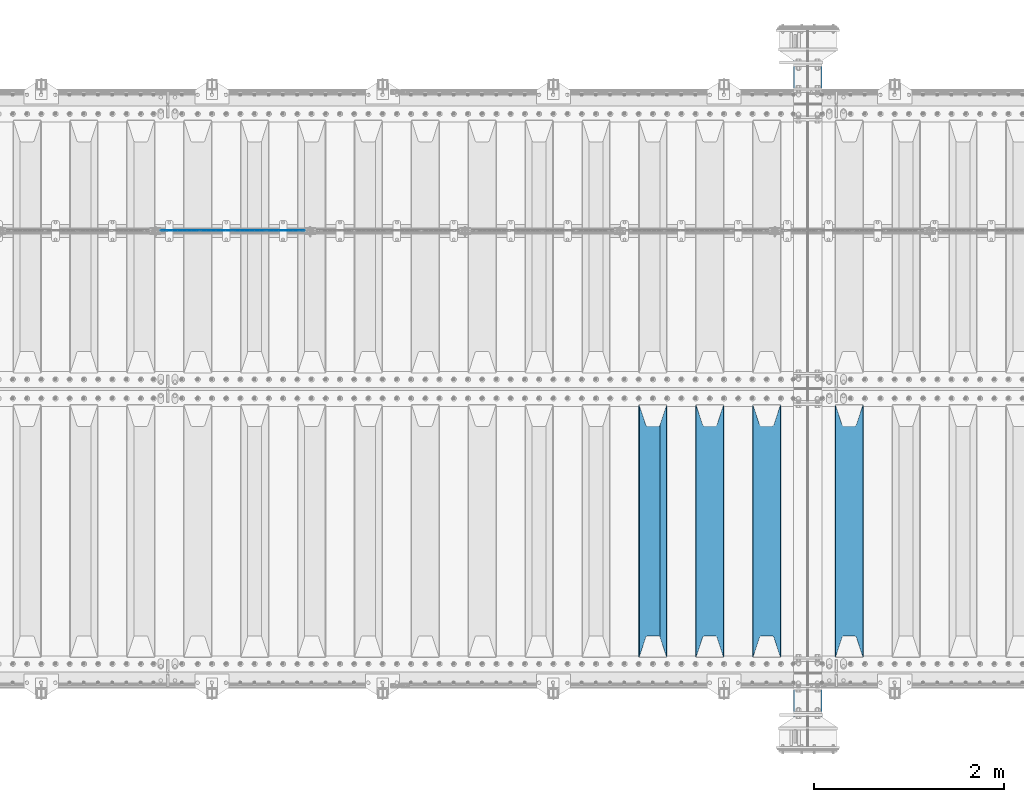
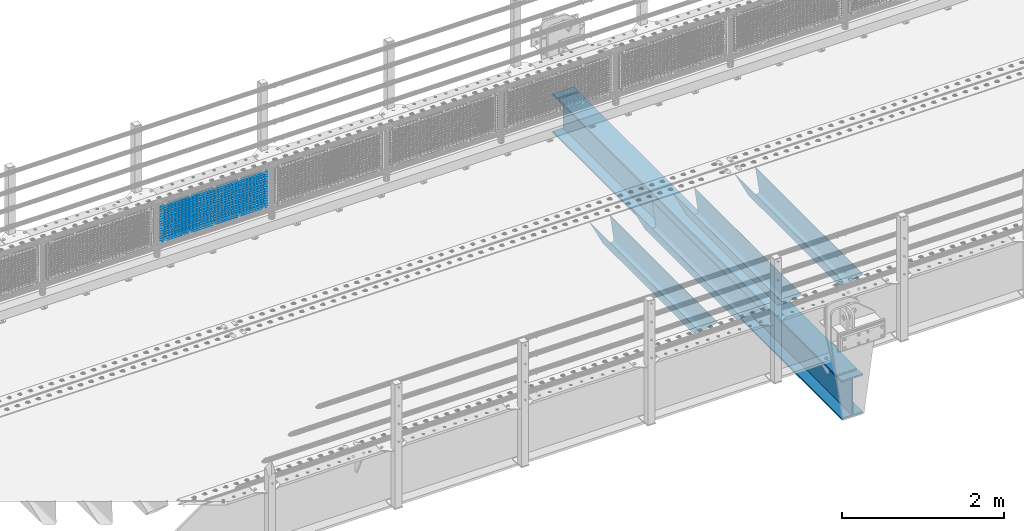
# One storey, part 121 of 242: 21 beams.
"""IFC2X3 building model written with IfcOpenShell, lengths in millimetres."""

import ifcopenshell
import ifcopenshell.guid

model = None  # the IFC model being written
_history = None  # IfcOwnerHistory: only IFC2X3 demands one
_inside = {}  # id of a spatial element -> (the spatial element, [elements in it])
_under = {}  # id of a project, library or spatial element -> (it, [spatial elements below it])
_declared = {}  # id of a project -> (the project, [libraries it declares])
_typed = {}  # id of a type object -> (the type object, [elements of that type])
_made_of = {}  # id of a material, layer set ... -> (it, [elements and type objects made of it])


def new_model(schema):
    """Start an empty IFC model of exactly this schema.

    Asked for "IFC4X3", IfcOpenShell would pick the latest addendum, in which some entities
    have other attributes; the version numbers below select the first issue.
    IFC2X3 requires an IfcOwnerHistory on every rooted entity: one is made here for all.
    """
    global model, _history
    if schema == "IFC4X3":
        model = ifcopenshell.file(schema_version=(4, 3, 0, 0))
    else:
        model = ifcopenshell.file(schema=schema)
    _inside.clear()
    _under.clear()
    _declared.clear()
    _typed.clear()
    _made_of.clear()
    _history = None
    if model.schema == "IFC2X3":
        org = make("IfcOrganization", Name="unknown")
        user = make(
            "IfcPersonAndOrganization",
            ThePerson=make("IfcPerson", FamilyName="unknown"),
            TheOrganization=org,
        )
        app = make(
            "IfcApplication",
            ApplicationDeveloper=org,
            Version="unknown",
            ApplicationFullName="unknown",
            ApplicationIdentifier="unknown",
        )
        _history = make(
            "IfcOwnerHistory",
            OwningUser=user,
            OwningApplication=app,
            ChangeAction="ADDED",
            CreationDate=0,
        )
    return model


def make(cls, **values):
    """One entity of the class cls with the attributes given. An attribute that is None is left unset."""
    return model.create_entity(
        cls, **{name: value for name, value in values.items() if value is not None}
    )


def rooted(cls, **values):
    """An entity with a GlobalId (a new one), such as an element, a storey or a relation."""
    return make(cls, GlobalId=ifcopenshell.guid.new(), OwnerHistory=_history, **values)


def si_unit(unit_type, name, prefix=None):
    """IfcSIUnit, for example si_unit("LENGTHUNIT", "METRE", prefix="MILLI")."""
    return make("IfcSIUnit", UnitType=unit_type, Prefix=prefix, Name=name)


def assignment(units):
    """IfcUnitAssignment: the units of a project."""
    return None if units is None else make("IfcUnitAssignment", Units=units)


def point(xyz):
    """IfcCartesianPoint."""
    return None if xyz is None else make("IfcCartesianPoint", Coordinates=xyz)


def direction(xyz):
    """IfcDirection."""
    return None if xyz is None else make("IfcDirection", DirectionRatios=xyz)


def frame(location, z_axis=None, x_axis=None):
    """IfcAxis2Placement3D, a coordinate frame: its origin and axes. An axis left out is left unset."""
    return make(
        "IfcAxis2Placement3D",
        Location=point(location),
        Axis=direction(z_axis),
        RefDirection=direction(x_axis),
    )


def origin_with_axes():
    """The frame at (0, 0, 0) with the z axis (0, 0, 1) and the x axis (1, 0, 0) written out."""
    return frame((0.0, 0.0, 0.0), z_axis=(0.0, 0.0, 1.0), x_axis=(1.0, 0.0, 0.0))


def place(relative_to, where):
    """IfcLocalPlacement: puts the frame where relative to a parent placement (None: the world)."""
    return make(
        "IfcLocalPlacement", PlacementRelTo=relative_to, RelativePlacement=where
    )


def context(
    kind, dimensions, precision=None, world=None, true_north=None, identifier=None
):
    """IfcGeometricRepresentationContext, for example the 3D "Model" context."""
    return make(
        "IfcGeometricRepresentationContext",
        ContextIdentifier=identifier,
        ContextType=kind,
        CoordinateSpaceDimension=dimensions,
        Precision=precision,
        WorldCoordinateSystem=world,
        TrueNorth=true_north,
    )


def subcontext(parent, identifier, kind, view, scale=None):
    """IfcGeometricRepresentationSubContext, for example "Body" below "Model"."""
    return make(
        "IfcGeometricRepresentationSubContext",
        ContextIdentifier=identifier,
        ContextType=kind,
        ParentContext=parent,
        TargetScale=scale,
        TargetView=view,
    )


def project(units=None, contexts=None):
    """IfcProject with its units and contexts."""
    return rooted(
        "IfcProject",
        Name="project",
        RepresentationContexts=contexts,
        UnitsInContext=assignment(units),
    )


def spatial(cls, under=None, at=None, **own):
    """A site, building, storey or space (cls), placed at a placement, below another one or the project."""
    s = rooted(cls, ObjectPlacement=at, **own)
    if under is not None:
        _under.setdefault(under.id(), (under, []))[1].append(s)
    return s


def faces_of(points, faces, orient=None, outer=None):
    """IfcFace entities. A face is a list of loops; a loop is a list of indices into points, from 0.

    orient and outer hold one flag for each loop. By default every Orientation is true, the
    first loop of a face is its IfcFaceOuterBound and the others are IfcFaceBound.
    """
    made = []
    for i, loops in enumerate(faces):
        bounds = []
        for j, loop in enumerate(loops):
            is_outer = j == 0 if outer is None else outer[i][j]
            bounds.append(
                make(
                    "IfcFaceOuterBound" if is_outer else "IfcFaceBound",
                    Bound=make("IfcPolyLoop", Polygon=[points[k] for k in loop]),
                    Orientation=True if orient is None else orient[i][j],
                )
            )
        made.append(make("IfcFace", Bounds=bounds))
    return made


def faceted_brep(points, faces, orient=None, outer=None, voids=None):
    """IfcFacetedBrep: a solid bounded by flat faces; with voids (closed shells), ...WithVoids."""
    shared = [point(p) for p in points]
    hull = make("IfcClosedShell", CfsFaces=faces_of(shared, faces, orient, outer))
    if voids is None:
        return make("IfcFacetedBrep", Outer=hull)
    return make(
        "IfcFacetedBrepWithVoids",
        Outer=hull,
        Voids=[
            make(cls, CfsFaces=faces_of(shared, fs, o, b)) for cls, fs, o, b in voids
        ],
    )


def shape(context_of_items, identifier, shape_type, items):
    """IfcShapeRepresentation: the items that make up one representation, for example the "Body"."""
    return make(
        "IfcShapeRepresentation",
        ContextOfItems=context_of_items,
        RepresentationIdentifier=identifier,
        RepresentationType=shape_type,
        Items=items,
    )


def material(Name=None, Category=None):
    """IfcMaterial."""
    return make("IfcMaterial", Name=Name, Category=Category)


def made_of(thing, what):
    """Note that an element or type object is made of a material, layer set ...; save() writes the relation."""
    if what is not None:
        _made_of.setdefault(what.id(), (what, []))[1].append(thing)
    return thing


def type_object(cls, material=None, **own):
    """A type object (cls), such as IfcWallType, which elements share."""
    return made_of(rooted(cls, **own), material)


def element(
    cls,
    number,
    at=None,
    inside=None,
    cuts=None,
    type_object=None,
    material=None,
    context=None,
    identifier="Body",
    shape_type=None,
    held_by="IfcProductDefinitionShape",
    body=None,
    shapes=None,
    **own,
):
    """One element of the class cls, such as IfcWall. Its Tag is "e" and its number.

    at: its placement. inside: the storey or other place that contains it. cuts: it is an
    opening in that element (IfcRelVoidsElement). A single representation is given by context,
    identifier, shape_type and body (its items); several are given by shapes. held_by: the class
    of the entity that holds the representations. save() writes the other relations.
    """
    e = rooted(cls, Tag="e%d" % number, ObjectPlacement=at, **own)
    if body is not None:
        shapes = [shape(context, identifier, shape_type, body)]
    if shapes is not None:
        e.Representation = make(held_by, Representations=shapes)
    if inside is not None:
        _inside.setdefault(inside.id(), (inside, []))[1].append(e)
    if cuts is not None:
        rooted(
            "IfcRelVoidsElement", RelatingBuildingElement=cuts, RelatedOpeningElement=e
        )
    if type_object is not None:
        _typed.setdefault(type_object.id(), (type_object, []))[1].append(e)
    return made_of(e, material)


def aggregate(whole, parts):
    """IfcRelAggregates: a whole, such as a stair, and the parts it consists of."""
    return rooted("IfcRelAggregates", RelatingObject=whole, RelatedObjects=parts)


def save(model, path):
    """Write the relations noted so far, then the file.

    IfcRelAggregates (storeys below a building ...), IfcRelContainedInSpatialStructure (elements
    in a storey), IfcRelDefinesByType, IfcRelAssociatesMaterial and IfcRelDeclares: one each for
    every whole, place, type object, material and project.
    """
    for whole, parts in _under.values():
        aggregate(whole, parts)
    for where, things in _inside.values():
        rooted(
            "IfcRelContainedInSpatialStructure",
            RelatedElements=things,
            RelatingStructure=where,
        )
    for kind, things in _typed.values():
        rooted("IfcRelDefinesByType", RelatedObjects=things, RelatingType=kind)
    for what, things in _made_of.values():
        rooted("IfcRelAssociatesMaterial", RelatedObjects=things, RelatingMaterial=what)
    for by, libraries in _declared.values():
        rooted("IfcRelDeclares", RelatingContext=by, RelatedDefinitions=libraries)
    model.write(path)


model = new_model("IFC2X3")

# Units and contexts
model_context = context("Model", 3, precision=1e-05, world=origin_with_axes())
body_context = subcontext(model_context, "Body", "Model", "MODEL_VIEW")
ifc_project = project(units=[si_unit("LENGTHUNIT", "METRE", prefix="MILLI"), si_unit("AREAUNIT", "SQUARE_METRE"), si_unit("VOLUMEUNIT", "CUBIC_METRE"), si_unit("MASSUNIT", "GRAM", prefix="KILO"), si_unit("TIMEUNIT", "SECOND"), si_unit("PLANEANGLEUNIT", "RADIAN"), si_unit("SOLIDANGLEUNIT", "STERADIAN"), si_unit("THERMODYNAMICTEMPERATUREUNIT", "DEGREE_CELSIUS"), si_unit("LUMINOUSINTENSITYUNIT", "LUMEN")], contexts=[model_context])

# Site, building, storey
site_placement = place(None, origin_with_axes())
site = spatial("IfcSite", under=ifc_project, at=site_placement, CompositionType="ELEMENT")
building_placement = place(site_placement, origin_with_axes())
building = spatial("IfcBuilding", under=site, at=building_placement, Name="Standard", CompositionType="ELEMENT")
storey_placement = place(building_placement, origin_with_axes())
storey = spatial("IfcBuildingStorey", under=building, at=storey_placement, Name="Undefined", CompositionType="ELEMENT", Elevation=0.0)

# Beams
ifc_material_1 = material(Name="Misc_Undefined")
beam_type_1 = type_object("IfcBeamType", Name="D3", PredefinedType="NOTDEFINED")
for number, where, z_axis, x_axis in (
    (1, (-35242.0, -19329.5, 851.596999999999), (0.0, 0.0, 1.0), (1.0, 0.0, 0.0)),
    (2, (-35242.0, -19329.5, 669.452), (0.0, 0.0, 1.0), (1.0, 0.0, 0.0)),
    (3, (-35242.0, -19329.5, 523.736), (0.0, 0.0, 1.0), (1.0, 0.0, 0.0)),
    (4, (-35242.0, -19329.5, 487.307), (0.0, 0.0, 1.0), (1.0, 0.0, 0.0)),
    (5, (-35242.0, -19329.5, 705.881), (0.0, 0.0, 1.0), (1.0, 0.0, 0.0)),
    (6, (-35242.0, -19329.5, 596.594), (0.0, 0.0, 1.0), (1.0, 0.0, 0.0)),
    (7, (-35242.0, -19329.5, 450.878), (0.0, 0.0, 1.0), (1.0, 0.0, 0.0)),
    (8, (-35242.0, -19329.5, 815.167999999999), (0.0, 0.0, 1.0), (1.0, 0.0, 0.0)),
    (9, (-35242.0, -19329.5, 888.025999999999), (0.0, 0.0, 1.0), (1.0, 0.0, 0.0)),
    (10, (-35242.0, -19329.5, 778.738999999999), (0.0, 0.0, 1.0), (1.0, 0.0, 0.0)),
    (11, (-35242.0, -19329.5, 742.309999999999), (0.0, 0.0, 1.0), (1.0, 0.0, 0.0)),
    (12, (-35242.0, -19329.5, 633.023), (0.0, 0.0, 1.0), (1.0, 0.0, 0.0)),
    (13, (-35242.0, -19329.5, 560.165), (0.0, 0.0, 1.0), (1.0, 0.0, 0.0)),
    (14, (-35242.0, -19329.5, 414.449), (0.0, 0.0, 1.0), (1.0, 0.0, 0.0)),
):
    element("IfcBeam", number, at=place(storey_placement, frame(where, z_axis=z_axis, x_axis=x_axis)), inside=storey, type_object=beam_type_1, material=ifc_material_1, ObjectType="D3", context=body_context, shape_type="Brep", body=[
        faceted_brep([(0.0, -1.50000000000364, 0.0), (-3.63797880709171e-12, -0.750000000003638, -1.29903810567669), (1523.0, -0.75, -1.29903810567669), (1523.0, -1.5, 0.0), (0.0, 0.749999999996362, -1.29903810567669), (1523.0, 0.75, -1.29903810567669), (-3.63797880709171e-12, 1.49999999999636, 0.0), (1523.0, 1.5, 0.0), (0.0, 0.749999999996362, 1.29903810567669), (1523.0, 0.75, 1.29903810567669), (-3.63797880709171e-12, -0.750000000003638, 1.29903810567669), (1523.0, -0.75, 1.29903810567669)], [[[0, 1, 2, 3]], [[1, 4, 5, 2]], [[4, 6, 7, 5]], [[6, 8, 9, 7]], [[8, 10, 11, 9]], [[10, 0, 3, 11]], [[5, 7, 9, 11, 3, 2]], [[10, 8, 6, 4, 1, 0]]]),
    ])
beam_1_placement = place(storey_placement, frame((-35217.0, -19329.5, 353.02), z_axis=(0.0, 0.0, 1.0), x_axis=(1.0, 0.0, 0.0)))
element("IfcBeam", 15, at=beam_1_placement, inside=storey, type_object=beam_type_1, material=ifc_material_1, ObjectType="D3", context=body_context, shape_type="Brep", body=[
    faceted_brep([(0.0, -1.50000000000364, 0.0), (-3.63797880709171e-12, -0.750000000003638, -1.29903810567669), (1473.0, -0.75, -1.29903810567669), (1473.0, -1.5, 0.0), (0.0, 0.749999999996362, -1.29903810567669), (1473.0, 0.75, -1.29903810567663), (-3.63797880709171e-12, 1.49999999999636, 0.0), (1473.0, 1.5, 0.0), (0.0, 0.749999999996362, 1.29903810567669), (1473.0, 0.75, 1.29903810567669), (-3.63797880709171e-12, -0.750000000003638, 1.29903810567669), (1473.0, -0.75, 1.29903810567669)], [[[0, 1, 2, 3]], [[1, 4, 5, 2]], [[4, 6, 7, 5]], [[6, 8, 9, 7]], [[8, 10, 11, 9]], [[10, 0, 3, 11]], [[5, 7, 9, 11, 3, 2]], [[10, 8, 6, 4, 1, 0]]]),
])
beam_2_placement = place(storey_placement, frame((-35242.0, -19329.5, 378.02), z_axis=(0.0, 0.0, 1.0), x_axis=(1.0, 0.0, 0.0)))
element("IfcBeam", 16, at=beam_2_placement, inside=storey, type_object=beam_type_1, material=ifc_material_1, ObjectType="D3", context=body_context, shape_type="Brep", body=[
    faceted_brep([(0.0, -1.50000000000364, 0.0), (-3.63797880709171e-12, -0.750000000003638, -1.29903810567669), (1523.0, -0.75, -1.29903810567669), (1523.0, -1.5, 0.0), (0.0, 0.749999999996362, -1.29903810567669), (1523.0, 0.75, -1.29903810567669), (-3.63797880709171e-12, 1.49999999999636, 0.0), (1523.0, 1.5, 0.0), (0.0, 0.749999999996362, 1.29903810567669), (1523.0, 0.75, 1.29903810567669), (-3.63797880709171e-12, -0.750000000003638, 1.29903810567669), (1523.0, -0.75, 1.29903810567669)], [[[0, 1, 2, 3]], [[1, 4, 5, 2]], [[4, 6, 7, 5]], [[6, 8, 9, 7]], [[8, 10, 11, 9]], [[10, 0, 3, 11]], [[5, 7, 9, 11, 3, 2]], [[10, 8, 6, 4, 1, 0]]]),
])
ifc_material_2 = material(Name="STEEL/S355N")
beam_type_2 = type_object("IfcBeamType", Name="HEA600", PredefinedType="NOTDEFINED")
beam_3_placement = place(storey_placement, frame((-28415.0000001802, -24564.9999999649, -1195.00001822199), z_axis=(0.0, 0.0, 1.0), x_axis=(0.0, 1.0, 0.0)))
element("IfcBeam", 17, at=beam_3_placement, inside=storey, type_object=beam_type_2, material=ifc_material_2, ObjectType="HEA600", context=body_context, shape_type="Brep", body=[
    faceted_brep([(6989.99999999952, -150.000000004802, 295.0), (6989.99999999952, -150.0, 270.0), (6989.99999999952, -6.5, 270.0), (6989.99999999952, -6.5, 295.0), (7019.99999999952, -6.5, 270.0), (7019.99999999952, -6.5, 295.0), (7019.99999999952, -150.0, 295.0), (7019.99999999952, -150.0, 270.0), (7129.99999999952, -150.0, 270.0), (7129.99999999952, -150.0, 295.0), (7129.99999999952, -6.5, 270.0), (7129.99999999952, 150.0, 295.0), (7129.99999999952, 150.0, 270.0), (7019.99999999952, 150.0, 270.0), (7019.99999999952, 150.0, 295.0), (140.000000044318, 6.5, 270.0), (140.000000324839, 150.0, 270.0), (6989.99999999952, 150.0, 270.0), (6989.99999999952, 6.5, 270.0), (0.0, -150.0, -295.0), (0.0, 150.0, -295.0), (7129.99999999952, 150.0, -295.0), (7129.99999999952, -150.0, -295.0), (7019.99999999952, -150.0, -270.0), (6989.99999999952, -150.0, -270.0), (139.999999738287, -150.0, -270.0), (109.999999738287, -150.0, -270.0), (0.0, -150.0, -270.0), (7129.99999999952, -150.0, -270.0), (7019.99999999952, -6.5, -270.0), (6989.99999999952, -6.5, -270.0), (140.000000025124, -6.5, -270.0), (110.000000025288, -6.5, -270.0), (0.0, -6.5, -270.0), (7129.99999999952, -6.5, -270.0), (0.0, -150.0, 270.0), (0.0, -6.5, 270.0), (110.000000025288, -6.5, 270.0), (109.999999738287, -150.0, 270.0), (139.999999738287, -150.00000023983, 295.0), (140.000000025124, -6.50000023983011, 295.0), (140.000000025124, -6.5, 270.0), (139.999999738287, -150.0, 270.0), (110.000000025288, -6.50000017982893, 295.0), (109.999999738287, -150.0, 295.0), (0.0, -150.0, 295.0), (0.0, 6.5, 270.0), (0.0, 150.0, 270.0), (110.000000324839, 150.0, 270.0), (110.000000324839, 6.5, 270.0), (0.0, 150.0, 295.0), (0.0, 6.5, -270.0), (0.0, 150.0, -270.0), (110.000000324839, 150.0, 295.0), (110.000000324839, 6.49999976097024, 295.0), (140.000000044318, 6.49999976097024, 295.0), (140.000000324839, 150.0, 295.0), (6989.99999999952, 150.0, 295.0), (6989.99999999952, 6.5, 295.0), (7019.99999999952, 6.5, 295.0), (7019.99999999952, 6.5, 270.0), (7129.99999999952, 6.5, 270.0), (7019.99999999952, 6.5, -270.0), (6989.99999999952, 6.5, -270.0), (140.000000044318, 6.5, -270.0), (110.000000324839, 6.5, -270.0), (7129.99999999952, 6.5, -270.0), (7019.99999999952, 150.0, -270.0), (6989.99999999952, 150.0, -270.0), (140.000000324839, 150.0, -270.0), (110.000000324839, 150.0, -270.0), (7129.99999999952, 150.0, -270.0)], [[[0, 1, 2, 3]], [[3, 2, 4, 5]], [[6, 5, 4, 7]], [[8, 9, 6, 7]], [[10, 8, 7, 4]], [[11, 12, 13, 14]], [[15, 16, 17, 18]], [[19, 20, 21, 22]], [[23, 24, 25, 26, 27, 19, 22, 28]], [[29, 30, 31, 32, 33, 27, 26, 25, 24, 23, 28, 34]], [[35, 36, 37, 38]], [[39, 40, 41, 42]], [[43, 37, 41, 40]], [[44, 38, 37, 43]], [[45, 35, 38, 44]], [[46, 47, 48, 49]], [[19, 27, 33, 36, 35, 45, 50, 47, 46, 51, 52, 20]], [[47, 50, 53, 48]], [[54, 49, 48, 53]], [[55, 15, 49, 54]], [[56, 16, 15, 55]], [[16, 56, 57, 17]], [[58, 18, 17, 57]], [[59, 60, 18, 58]], [[14, 13, 60, 59]], [[12, 61, 60, 13]], [[62, 63, 64, 65, 51, 46, 49, 15, 18, 60, 61, 66]], [[67, 68, 69, 70, 52, 51, 65, 64, 63, 62, 66, 71]], [[20, 52, 70, 69, 68, 67, 71, 21]], [[66, 61, 12, 11, 9, 8, 10, 34, 28, 22, 21, 71]], [[4, 2, 41, 37, 36, 33, 32, 31, 30, 29, 34, 10]], [[42, 41, 2, 1]], [[39, 42, 1, 0]], [[9, 11, 14, 59, 58, 57, 56, 55, 54, 53, 50, 45, 44, 43, 40, 39, 0, 3, 5, 6]]]),
])
beam_type_3 = type_object("IfcBeamType", PredefinedType="NOTDEFINED")
beam_4_placement = place(storey_placement, frame((-27980.0, -23825.0, -115.0), z_axis=(0.0, 0.0, 1.0), x_axis=(0.0, 1.0, 0.0)))
element("IfcBeam", 18, at=beam_4_placement, inside=storey, type_object=beam_type_3, material=ifc_material_2, context=body_context, shape_type="Brep", body=[
    faceted_brep([(0.0, 150.0, 115.0), (0.0, 143.689999999999, 115.0), (2650.00000000297, 143.689999999999, 115.0), (2650.00000000297, 150.0, 115.0), (2650.00000000297, 142.059565218402, 110.000000003099), (2650.00000000297, 148.369565218403, 110.000000003099), (2441.90079219209, -80.1103600731112, -98.0992078077845), (2437.7588105432, -77.5672621345584, -102.241189456673), (2434.06523489747, -74.4080125315522, -105.934765102404), (2430.91086095089, -70.710272125576, -109.089139048974), (2428.37322971128, -66.5649389910068, -111.626770288588), (2426.51472138055, -62.0739139532889, -113.485278619323), (2425.38102192092, -57.3475956567672, -114.618978078955), (2424.99999999987, -52.5021667386536, -115.0), (2424.99999999987, 52.5021667386536, -115.0), (2425.38102192092, 57.3475956567672, -114.618978078955), (2426.51472138055, 62.0739139532889, -113.485278619323), (2428.37322971128, 66.5649389910068, -111.626770288588), (2430.91086095089, 70.710272125576, -109.089139048974), (2434.06523489747, 74.4080125315522, -105.934765102404), (2437.7588105432, 77.5672621345584, -102.241189456673), (2441.90079219209, 80.1103600731112, -98.0992078077846), (2446.38936140511, 81.9747917625791, -93.6106385947584), (2448.2494850041, 76.2713538057251, -91.7505149957729), (2444.62967112262, 74.76777986261, -95.3703288772456), (2441.28936334126, 72.7168944282894, -98.710636658607), (2438.31067330438, 70.1691124903846, -101.689326695487), (2435.76682334747, 67.1870637758839, -104.233176652398), (2433.72034654133, 63.8440531834895, -106.279653458539), (2432.22154950042, 60.222258798236, -107.778450499454), (2431.30727574265, 56.4107117849089, -108.692724257221), (2430.99999999987, 52.5031078186876, -109.0), (2430.99999999987, -52.5031078186876, -109.0), (2431.30727574265, -56.4107117849089, -108.692724257221), (2432.22154950042, -60.222258798236, -107.778450499454), (2433.72034654133, -63.8440531834895, -106.279653458539), (2435.76682334747, -67.1870637758839, -104.233176652398), (2438.31067330438, -70.1691124903846, -101.689326695487), (2441.28936334126, -72.7168944282894, -98.7106366586071), (2444.62967112262, -74.76777986261, -95.3703288772457), (2448.2494850041, -76.2713538057251, -91.7505149957729), (2650.00000000297, -142.059565218402, 110.000000003099), (2650.00000000297, -148.369565218403, 110.000000003099), (2446.38936140511, -81.9747917625791, -93.6106385947584), (2650.00000000297, -143.689999999999, 115.0), (2650.00000000297, -150.0, 115.0), (0.0, -143.689999999999, 115.0), (0.0, -150.0, 115.0), (0.0, -148.369565218261, 110.000000002669), (203.610638597427, -81.9747917625791, -93.6106385947584), (208.099207810454, -80.1103600731112, -98.0992078077845), (212.241189459342, -77.5672621345584, -102.241189456673), (215.934765105074, -74.4080125315522, -105.934765102404), (219.089139051644, -70.710272125576, -109.089139048974), (221.626770291256, -66.5649389910068, -111.626770288588), (223.485278621993, -62.0739139532889, -113.485278619323), (224.618978081624, -57.3475956567672, -114.618978078955), (225.00000000267, -52.5021667386536, -115.0), (225.00000000267, 52.5021667386536, -115.0), (224.618978081624, 57.3475956567672, -114.618978078955), (223.485278621993, 62.0739139532889, -113.485278619323), (221.626770291256, 66.5649389910068, -111.626770288588), (219.089139051644, 70.710272125576, -109.089139048974), (215.934765105074, 74.4080125315522, -105.934765102404), (212.241189459342, 77.5672621345584, -102.241189456673), (208.099207810454, 80.1103600731112, -98.0992078077846), (203.610638597427, 81.9747917625791, -93.6106385947584), (0.0, 148.369565218261, 110.000000002669), (0.0, 142.05956521826, 110.000000002669), (201.750514998443, 76.2713538057251, -91.7505149957729), (205.370328879915, 74.76777986261, -95.3703288772456), (208.710636661275, 72.7168944282894, -98.710636658607), (211.689326698157, 70.1691124903846, -101.689326695487), (214.233176655067, 67.1870637758839, -104.233176652398), (216.279653461206, 63.8440531834895, -106.279653458539), (217.778450502123, 60.222258798236, -107.778450499454), (218.69272425989, 56.4107117849089, -108.692724257221), (219.00000000267, 52.5031078186876, -109.0), (219.00000000267, -52.5031078186876, -109.0), (218.69272425989, -56.4107117849089, -108.692724257221), (217.778450502123, -60.222258798236, -107.778450499454), (216.279653461206, -63.8440531834895, -106.279653458539), (214.233176655067, -67.1870637758839, -104.233176652398), (211.689326698157, -70.1691124903846, -101.689326695487), (208.710636661275, -72.7168944282894, -98.7106366586071), (205.370328879915, -74.76777986261, -95.3703288772457), (201.750514998443, -76.2713538057251, -91.7505149957729), (0.0, -142.05956521826, 110.000000002669)], [[[0, 1, 2, 3]], [[3, 2, 4, 5]], [[6, 7, 8, 9, 10, 11, 12, 13, 14, 15, 16, 17, 18, 19, 20, 21, 22, 5, 4, 23, 24, 25, 26, 27, 28, 29, 30, 31, 32, 33, 34, 35, 36, 37, 38, 39, 40, 41, 42, 43]], [[44, 45, 42, 41]], [[46, 47, 45, 44]], [[43, 42, 45, 47, 48, 49]], [[6, 43, 49, 50]], [[7, 6, 50, 51]], [[8, 7, 51, 52]], [[9, 8, 52, 53]], [[10, 9, 53, 54]], [[11, 10, 54, 55]], [[12, 11, 55, 56]], [[13, 12, 56, 57]], [[14, 13, 57, 58]], [[15, 14, 58, 59]], [[16, 15, 59, 60]], [[17, 16, 60, 61]], [[18, 17, 61, 62]], [[19, 18, 62, 63]], [[20, 19, 63, 64]], [[21, 20, 64, 65]], [[22, 21, 65, 66]], [[0, 3, 5, 22, 66, 67]], [[1, 0, 67, 68]], [[23, 4, 2, 1, 68, 69]], [[24, 23, 69, 70]], [[25, 24, 70, 71]], [[26, 25, 71, 72]], [[27, 26, 72, 73]], [[28, 27, 73, 74]], [[29, 28, 74, 75]], [[30, 29, 75, 76]], [[31, 30, 76, 77]], [[32, 31, 77, 78]], [[33, 32, 78, 79]], [[34, 33, 79, 80]], [[35, 34, 80, 81]], [[36, 35, 81, 82]], [[37, 36, 82, 83]], [[38, 37, 83, 84]], [[39, 38, 84, 85]], [[40, 39, 85, 86]], [[46, 44, 41, 40, 86, 87]], [[47, 46, 87, 48]], [[86, 85, 84, 83, 82, 81, 80, 79, 78, 77, 76, 75, 74, 73, 72, 71, 70, 69, 68, 67, 66, 65, 64, 63, 62, 61, 60, 59, 58, 57, 56, 55, 54, 53, 52, 51, 50, 49, 48, 87]]]),
])
beam_5_placement = place(storey_placement, frame((-28850.0, -23825.0, -115.0), z_axis=(0.0, 0.0, 1.0), x_axis=(0.0, 1.0, 0.0)))
element("IfcBeam", 19, at=beam_5_placement, inside=storey, type_object=beam_type_3, material=ifc_material_2, context=body_context, shape_type="Brep", body=[
    faceted_brep([(0.0, 150.0, 115.0), (0.0, 143.689999999999, 115.0), (2650.00000000297, 143.689999999999, 115.0), (2650.00000000297, 150.0, 115.0), (2650.00000000297, 142.059565218402, 110.000000003099), (2650.00000000297, 148.369565218403, 110.000000003099), (2441.90079219209, -80.1103600731112, -98.0992078077845), (2437.7588105432, -77.5672621345584, -102.241189456673), (2434.06523489747, -74.4080125315522, -105.934765102404), (2430.91086095089, -70.710272125576, -109.089139048974), (2428.37322971128, -66.5649389910068, -111.626770288588), (2426.51472138055, -62.0739139532889, -113.485278619323), (2425.38102192092, -57.3475956567672, -114.618978078955), (2424.99999999987, -52.5021667386536, -115.0), (2424.99999999987, 52.5021667386536, -115.0), (2425.38102192092, 57.3475956567672, -114.618978078955), (2426.51472138055, 62.0739139532889, -113.485278619323), (2428.37322971128, 66.5649389910068, -111.626770288588), (2430.91086095089, 70.710272125576, -109.089139048974), (2434.06523489747, 74.4080125315522, -105.934765102404), (2437.7588105432, 77.5672621345584, -102.241189456673), (2441.90079219209, 80.1103600731112, -98.0992078077846), (2446.38936140511, 81.9747917625791, -93.6106385947584), (2448.2494850041, 76.2713538057251, -91.7505149957729), (2444.62967112262, 74.76777986261, -95.3703288772456), (2441.28936334126, 72.7168944282894, -98.710636658607), (2438.31067330438, 70.1691124903846, -101.689326695487), (2435.76682334747, 67.1870637758839, -104.233176652398), (2433.72034654133, 63.8440531834895, -106.279653458539), (2432.22154950042, 60.222258798236, -107.778450499454), (2431.30727574265, 56.4107117849089, -108.692724257221), (2430.99999999987, 52.5031078186876, -109.0), (2430.99999999987, -52.5031078186876, -109.0), (2431.30727574265, -56.4107117849089, -108.692724257221), (2432.22154950042, -60.222258798236, -107.778450499454), (2433.72034654133, -63.8440531834895, -106.279653458539), (2435.76682334747, -67.1870637758839, -104.233176652398), (2438.31067330438, -70.1691124903846, -101.689326695487), (2441.28936334126, -72.7168944282894, -98.7106366586071), (2444.62967112262, -74.76777986261, -95.3703288772457), (2448.2494850041, -76.2713538057251, -91.7505149957729), (2650.00000000297, -142.059565218402, 110.000000003099), (2650.00000000297, -148.369565218403, 110.000000003099), (2446.38936140511, -81.9747917625791, -93.6106385947584), (2650.00000000297, -143.689999999999, 115.0), (2650.00000000297, -150.0, 115.0), (0.0, -143.689999999999, 115.0), (0.0, -150.0, 115.0), (0.0, -148.369565218261, 110.000000002669), (203.610638597427, -81.9747917625791, -93.6106385947584), (208.099207810454, -80.1103600731112, -98.0992078077845), (212.241189459342, -77.5672621345584, -102.241189456673), (215.934765105074, -74.4080125315522, -105.934765102404), (219.089139051644, -70.710272125576, -109.089139048974), (221.626770291256, -66.5649389910068, -111.626770288588), (223.485278621993, -62.0739139532889, -113.485278619323), (224.618978081624, -57.3475956567672, -114.618978078955), (225.00000000267, -52.5021667386536, -115.0), (225.00000000267, 52.5021667386536, -115.0), (224.618978081624, 57.3475956567672, -114.618978078955), (223.485278621993, 62.0739139532889, -113.485278619323), (221.626770291256, 66.5649389910068, -111.626770288588), (219.089139051644, 70.710272125576, -109.089139048974), (215.934765105074, 74.4080125315522, -105.934765102404), (212.241189459342, 77.5672621345584, -102.241189456673), (208.099207810454, 80.1103600731112, -98.0992078077846), (203.610638597427, 81.9747917625791, -93.6106385947584), (0.0, 148.369565218261, 110.000000002669), (0.0, 142.05956521826, 110.000000002669), (201.750514998443, 76.2713538057251, -91.7505149957729), (205.370328879915, 74.76777986261, -95.3703288772456), (208.710636661275, 72.7168944282894, -98.710636658607), (211.689326698157, 70.1691124903846, -101.689326695487), (214.233176655067, 67.1870637758839, -104.233176652398), (216.279653461206, 63.8440531834895, -106.279653458539), (217.778450502123, 60.222258798236, -107.778450499454), (218.69272425989, 56.4107117849089, -108.692724257221), (219.00000000267, 52.5031078186876, -109.0), (219.00000000267, -52.5031078186876, -109.0), (218.69272425989, -56.4107117849089, -108.692724257221), (217.778450502123, -60.222258798236, -107.778450499454), (216.279653461206, -63.8440531834895, -106.279653458539), (214.233176655067, -67.1870637758839, -104.233176652398), (211.689326698157, -70.1691124903846, -101.689326695487), (208.710636661275, -72.7168944282894, -98.7106366586071), (205.370328879915, -74.76777986261, -95.3703288772457), (201.750514998443, -76.2713538057251, -91.7505149957729), (0.0, -142.05956521826, 110.000000002669)], [[[0, 1, 2, 3]], [[3, 2, 4, 5]], [[6, 7, 8, 9, 10, 11, 12, 13, 14, 15, 16, 17, 18, 19, 20, 21, 22, 5, 4, 23, 24, 25, 26, 27, 28, 29, 30, 31, 32, 33, 34, 35, 36, 37, 38, 39, 40, 41, 42, 43]], [[44, 45, 42, 41]], [[46, 47, 45, 44]], [[43, 42, 45, 47, 48, 49]], [[6, 43, 49, 50]], [[7, 6, 50, 51]], [[8, 7, 51, 52]], [[9, 8, 52, 53]], [[10, 9, 53, 54]], [[11, 10, 54, 55]], [[12, 11, 55, 56]], [[13, 12, 56, 57]], [[14, 13, 57, 58]], [[15, 14, 58, 59]], [[16, 15, 59, 60]], [[17, 16, 60, 61]], [[18, 17, 61, 62]], [[19, 18, 62, 63]], [[20, 19, 63, 64]], [[21, 20, 64, 65]], [[22, 21, 65, 66]], [[0, 3, 5, 22, 66, 67]], [[1, 0, 67, 68]], [[23, 4, 2, 1, 68, 69]], [[24, 23, 69, 70]], [[25, 24, 70, 71]], [[26, 25, 71, 72]], [[27, 26, 72, 73]], [[28, 27, 73, 74]], [[29, 28, 74, 75]], [[30, 29, 75, 76]], [[31, 30, 76, 77]], [[32, 31, 77, 78]], [[33, 32, 78, 79]], [[34, 33, 79, 80]], [[35, 34, 80, 81]], [[36, 35, 81, 82]], [[37, 36, 82, 83]], [[38, 37, 83, 84]], [[39, 38, 84, 85]], [[40, 39, 85, 86]], [[46, 44, 41, 40, 86, 87]], [[47, 46, 87, 48]], [[86, 85, 84, 83, 82, 81, 80, 79, 78, 77, 76, 75, 74, 73, 72, 71, 70, 69, 68, 67, 66, 65, 64, 63, 62, 61, 60, 59, 58, 57, 56, 55, 54, 53, 52, 51, 50, 49, 48, 87]]]),
])
beam_6_placement = place(storey_placement, frame((-29450.0, -23825.0, -115.0), z_axis=(0.0, 0.0, 1.0), x_axis=(0.0, 1.0, 0.0)))
element("IfcBeam", 20, at=beam_6_placement, inside=storey, type_object=beam_type_3, material=ifc_material_2, context=body_context, shape_type="Brep", body=[
    faceted_brep([(0.0, 150.0, 115.0), (0.0, 143.689999999999, 115.0), (2650.00000000297, 143.689999999999, 115.0), (2650.00000000297, 150.0, 115.0), (2650.00000000297, 142.059565218402, 110.000000003099), (2650.00000000297, 148.369565218403, 110.000000003099), (2441.90079219209, -80.1103600731112, -98.0992078077845), (2437.7588105432, -77.5672621345584, -102.241189456673), (2434.06523489747, -74.4080125315522, -105.934765102404), (2430.91086095089, -70.710272125576, -109.089139048974), (2428.37322971128, -66.5649389910068, -111.626770288588), (2426.51472138055, -62.0739139532889, -113.485278619323), (2425.38102192092, -57.3475956567672, -114.618978078955), (2424.99999999987, -52.5021667386536, -115.0), (2424.99999999987, 52.5021667386536, -115.0), (2425.38102192092, 57.3475956567672, -114.618978078955), (2426.51472138055, 62.0739139532889, -113.485278619323), (2428.37322971128, 66.5649389910068, -111.626770288588), (2430.91086095089, 70.710272125576, -109.089139048974), (2434.06523489747, 74.4080125315522, -105.934765102404), (2437.7588105432, 77.5672621345584, -102.241189456673), (2441.90079219209, 80.1103600731112, -98.0992078077846), (2446.38936140511, 81.9747917625791, -93.6106385947584), (2448.2494850041, 76.2713538057251, -91.7505149957729), (2444.62967112262, 74.76777986261, -95.3703288772456), (2441.28936334126, 72.7168944282894, -98.710636658607), (2438.31067330438, 70.1691124903846, -101.689326695487), (2435.76682334747, 67.1870637758839, -104.233176652398), (2433.72034654133, 63.8440531834895, -106.279653458539), (2432.22154950042, 60.222258798236, -107.778450499454), (2431.30727574265, 56.4107117849089, -108.692724257221), (2430.99999999987, 52.5031078186876, -109.0), (2430.99999999987, -52.5031078186876, -109.0), (2431.30727574265, -56.4107117849089, -108.692724257221), (2432.22154950042, -60.222258798236, -107.778450499454), (2433.72034654133, -63.8440531834895, -106.279653458539), (2435.76682334747, -67.1870637758839, -104.233176652398), (2438.31067330438, -70.1691124903846, -101.689326695487), (2441.28936334126, -72.7168944282894, -98.7106366586071), (2444.62967112262, -74.76777986261, -95.3703288772457), (2448.2494850041, -76.2713538057251, -91.7505149957729), (2650.00000000297, -142.059565218402, 110.000000003099), (2650.00000000297, -148.369565218403, 110.000000003099), (2446.38936140511, -81.9747917625791, -93.6106385947584), (2650.00000000297, -143.689999999999, 115.0), (2650.00000000297, -150.0, 115.0), (0.0, -143.689999999999, 115.0), (0.0, -150.0, 115.0), (0.0, -148.369565218261, 110.000000002669), (203.610638597427, -81.9747917625791, -93.6106385947584), (208.099207810454, -80.1103600731112, -98.0992078077845), (212.241189459342, -77.5672621345584, -102.241189456673), (215.934765105074, -74.4080125315522, -105.934765102404), (219.089139051644, -70.710272125576, -109.089139048974), (221.626770291256, -66.5649389910068, -111.626770288588), (223.485278621993, -62.0739139532889, -113.485278619323), (224.618978081624, -57.3475956567672, -114.618978078955), (225.00000000267, -52.5021667386536, -115.0), (225.00000000267, 52.5021667386536, -115.0), (224.618978081624, 57.3475956567672, -114.618978078955), (223.485278621993, 62.0739139532889, -113.485278619323), (221.626770291256, 66.5649389910068, -111.626770288588), (219.089139051644, 70.710272125576, -109.089139048974), (215.934765105074, 74.4080125315522, -105.934765102404), (212.241189459342, 77.5672621345584, -102.241189456673), (208.099207810454, 80.1103600731112, -98.0992078077846), (203.610638597427, 81.9747917625791, -93.6106385947584), (0.0, 148.369565218261, 110.000000002669), (0.0, 142.05956521826, 110.000000002669), (201.750514998443, 76.2713538057251, -91.7505149957729), (205.370328879915, 74.76777986261, -95.3703288772456), (208.710636661275, 72.7168944282894, -98.710636658607), (211.689326698157, 70.1691124903846, -101.689326695487), (214.233176655067, 67.1870637758839, -104.233176652398), (216.279653461206, 63.8440531834895, -106.279653458539), (217.778450502123, 60.222258798236, -107.778450499454), (218.69272425989, 56.4107117849089, -108.692724257221), (219.00000000267, 52.5031078186876, -109.0), (219.00000000267, -52.5031078186876, -109.0), (218.69272425989, -56.4107117849089, -108.692724257221), (217.778450502123, -60.222258798236, -107.778450499454), (216.279653461206, -63.8440531834895, -106.279653458539), (214.233176655067, -67.1870637758839, -104.233176652398), (211.689326698157, -70.1691124903846, -101.689326695487), (208.710636661275, -72.7168944282894, -98.7106366586071), (205.370328879915, -74.76777986261, -95.3703288772457), (201.750514998443, -76.2713538057251, -91.7505149957729), (0.0, -142.05956521826, 110.000000002669)], [[[0, 1, 2, 3]], [[3, 2, 4, 5]], [[6, 7, 8, 9, 10, 11, 12, 13, 14, 15, 16, 17, 18, 19, 20, 21, 22, 5, 4, 23, 24, 25, 26, 27, 28, 29, 30, 31, 32, 33, 34, 35, 36, 37, 38, 39, 40, 41, 42, 43]], [[44, 45, 42, 41]], [[46, 47, 45, 44]], [[43, 42, 45, 47, 48, 49]], [[6, 43, 49, 50]], [[7, 6, 50, 51]], [[8, 7, 51, 52]], [[9, 8, 52, 53]], [[10, 9, 53, 54]], [[11, 10, 54, 55]], [[12, 11, 55, 56]], [[13, 12, 56, 57]], [[14, 13, 57, 58]], [[15, 14, 58, 59]], [[16, 15, 59, 60]], [[17, 16, 60, 61]], [[18, 17, 61, 62]], [[19, 18, 62, 63]], [[20, 19, 63, 64]], [[21, 20, 64, 65]], [[22, 21, 65, 66]], [[0, 3, 5, 22, 66, 67]], [[1, 0, 67, 68]], [[23, 4, 2, 1, 68, 69]], [[24, 23, 69, 70]], [[25, 24, 70, 71]], [[26, 25, 71, 72]], [[27, 26, 72, 73]], [[28, 27, 73, 74]], [[29, 28, 74, 75]], [[30, 29, 75, 76]], [[31, 30, 76, 77]], [[32, 31, 77, 78]], [[33, 32, 78, 79]], [[34, 33, 79, 80]], [[35, 34, 80, 81]], [[36, 35, 81, 82]], [[37, 36, 82, 83]], [[38, 37, 83, 84]], [[39, 38, 84, 85]], [[40, 39, 85, 86]], [[46, 44, 41, 40, 86, 87]], [[47, 46, 87, 48]], [[86, 85, 84, 83, 82, 81, 80, 79, 78, 77, 76, 75, 74, 73, 72, 71, 70, 69, 68, 67, 66, 65, 64, 63, 62, 61, 60, 59, 58, 57, 56, 55, 54, 53, 52, 51, 50, 49, 48, 87]]]),
])
beam_7_placement = place(storey_placement, frame((-30050.0, -23825.0, -115.0), z_axis=(0.0, 0.0, 1.0), x_axis=(0.0, 1.0, 0.0)))
element("IfcBeam", 21, at=beam_7_placement, inside=storey, type_object=beam_type_3, material=ifc_material_2, context=body_context, shape_type="Brep", body=[
    faceted_brep([(0.0, 150.0, 115.0), (0.0, 143.689999999999, 115.0), (2650.00000000297, 143.689999999999, 115.0), (2650.00000000297, 150.0, 115.0), (2650.00000000297, 142.059565218402, 110.000000003099), (2650.00000000297, 148.369565218403, 110.000000003099), (2441.90079219209, -80.1103600731112, -98.0992078077845), (2437.7588105432, -77.5672621345584, -102.241189456673), (2434.06523489747, -74.4080125315522, -105.934765102404), (2430.91086095089, -70.710272125576, -109.089139048974), (2428.37322971128, -66.5649389910068, -111.626770288588), (2426.51472138055, -62.0739139532889, -113.485278619323), (2425.38102192092, -57.3475956567672, -114.618978078955), (2424.99999999987, -52.5021667386536, -115.0), (2424.99999999987, 52.5021667386536, -115.0), (2425.38102192092, 57.3475956567672, -114.618978078955), (2426.51472138055, 62.0739139532889, -113.485278619323), (2428.37322971128, 66.5649389910068, -111.626770288588), (2430.91086095089, 70.710272125576, -109.089139048974), (2434.06523489747, 74.4080125315522, -105.934765102404), (2437.7588105432, 77.5672621345584, -102.241189456673), (2441.90079219209, 80.1103600731112, -98.0992078077846), (2446.38936140511, 81.9747917625791, -93.6106385947584), (2448.2494850041, 76.2713538057251, -91.7505149957729), (2444.62967112262, 74.76777986261, -95.3703288772456), (2441.28936334126, 72.7168944282894, -98.710636658607), (2438.31067330438, 70.1691124903846, -101.689326695487), (2435.76682334747, 67.1870637758839, -104.233176652398), (2433.72034654133, 63.8440531834895, -106.279653458539), (2432.22154950042, 60.222258798236, -107.778450499454), (2431.30727574265, 56.4107117849089, -108.692724257221), (2430.99999999987, 52.5031078186876, -109.0), (2430.99999999987, -52.5031078186876, -109.0), (2431.30727574265, -56.4107117849089, -108.692724257221), (2432.22154950042, -60.222258798236, -107.778450499454), (2433.72034654133, -63.8440531834895, -106.279653458539), (2435.76682334747, -67.1870637758839, -104.233176652398), (2438.31067330438, -70.1691124903846, -101.689326695487), (2441.28936334126, -72.7168944282894, -98.7106366586071), (2444.62967112262, -74.76777986261, -95.3703288772457), (2448.2494850041, -76.2713538057251, -91.7505149957729), (2650.00000000297, -142.059565218402, 110.000000003099), (2650.00000000297, -148.369565218403, 110.000000003099), (2446.38936140511, -81.9747917625791, -93.6106385947584), (2650.00000000297, -143.689999999999, 115.0), (2650.00000000297, -150.0, 115.0), (0.0, -143.689999999999, 115.0), (0.0, -150.0, 115.0), (0.0, -148.369565218261, 110.000000002669), (203.610638597427, -81.9747917625791, -93.6106385947584), (208.099207810454, -80.1103600731112, -98.0992078077845), (212.241189459342, -77.5672621345584, -102.241189456673), (215.934765105074, -74.4080125315522, -105.934765102404), (219.089139051644, -70.710272125576, -109.089139048974), (221.626770291256, -66.5649389910068, -111.626770288588), (223.485278621993, -62.0739139532889, -113.485278619323), (224.618978081624, -57.3475956567672, -114.618978078955), (225.00000000267, -52.5021667386536, -115.0), (225.00000000267, 52.5021667386536, -115.0), (224.618978081624, 57.3475956567672, -114.618978078955), (223.485278621993, 62.0739139532889, -113.485278619323), (221.626770291256, 66.5649389910068, -111.626770288588), (219.089139051644, 70.710272125576, -109.089139048974), (215.934765105074, 74.4080125315522, -105.934765102404), (212.241189459342, 77.5672621345584, -102.241189456673), (208.099207810454, 80.1103600731112, -98.0992078077846), (203.610638597427, 81.9747917625791, -93.6106385947584), (0.0, 148.369565218261, 110.000000002669), (0.0, 142.05956521826, 110.000000002669), (201.750514998443, 76.2713538057251, -91.7505149957729), (205.370328879915, 74.76777986261, -95.3703288772456), (208.710636661275, 72.7168944282894, -98.710636658607), (211.689326698157, 70.1691124903846, -101.689326695487), (214.233176655067, 67.1870637758839, -104.233176652398), (216.279653461206, 63.8440531834895, -106.279653458539), (217.778450502123, 60.222258798236, -107.778450499454), (218.69272425989, 56.4107117849089, -108.692724257221), (219.00000000267, 52.5031078186876, -109.0), (219.00000000267, -52.5031078186876, -109.0), (218.69272425989, -56.4107117849089, -108.692724257221), (217.778450502123, -60.222258798236, -107.778450499454), (216.279653461206, -63.8440531834895, -106.279653458539), (214.233176655067, -67.1870637758839, -104.233176652398), (211.689326698157, -70.1691124903846, -101.689326695487), (208.710636661275, -72.7168944282894, -98.7106366586071), (205.370328879915, -74.76777986261, -95.3703288772457), (201.750514998443, -76.2713538057251, -91.7505149957729), (0.0, -142.05956521826, 110.000000002669)], [[[0, 1, 2, 3]], [[3, 2, 4, 5]], [[6, 7, 8, 9, 10, 11, 12, 13, 14, 15, 16, 17, 18, 19, 20, 21, 22, 5, 4, 23, 24, 25, 26, 27, 28, 29, 30, 31, 32, 33, 34, 35, 36, 37, 38, 39, 40, 41, 42, 43]], [[44, 45, 42, 41]], [[46, 47, 45, 44]], [[43, 42, 45, 47, 48, 49]], [[6, 43, 49, 50]], [[7, 6, 50, 51]], [[8, 7, 51, 52]], [[9, 8, 52, 53]], [[10, 9, 53, 54]], [[11, 10, 54, 55]], [[12, 11, 55, 56]], [[13, 12, 56, 57]], [[14, 13, 57, 58]], [[15, 14, 58, 59]], [[16, 15, 59, 60]], [[17, 16, 60, 61]], [[18, 17, 61, 62]], [[19, 18, 62, 63]], [[20, 19, 63, 64]], [[21, 20, 64, 65]], [[22, 21, 65, 66]], [[0, 3, 5, 22, 66, 67]], [[1, 0, 67, 68]], [[23, 4, 2, 1, 68, 69]], [[24, 23, 69, 70]], [[25, 24, 70, 71]], [[26, 25, 71, 72]], [[27, 26, 72, 73]], [[28, 27, 73, 74]], [[29, 28, 74, 75]], [[30, 29, 75, 76]], [[31, 30, 76, 77]], [[32, 31, 77, 78]], [[33, 32, 78, 79]], [[34, 33, 79, 80]], [[35, 34, 80, 81]], [[36, 35, 81, 82]], [[37, 36, 82, 83]], [[38, 37, 83, 84]], [[39, 38, 84, 85]], [[40, 39, 85, 86]], [[46, 44, 41, 40, 86, 87]], [[47, 46, 87, 48]], [[86, 85, 84, 83, 82, 81, 80, 79, 78, 77, 76, 75, 74, 73, 72, 71, 70, 69, 68, 67, 66, 65, 64, 63, 62, 61, 60, 59, 58, 57, 56, 55, 54, 53, 52, 51, 50, 49, 48, 87]]]),
])

save(model, "model.ifc")
